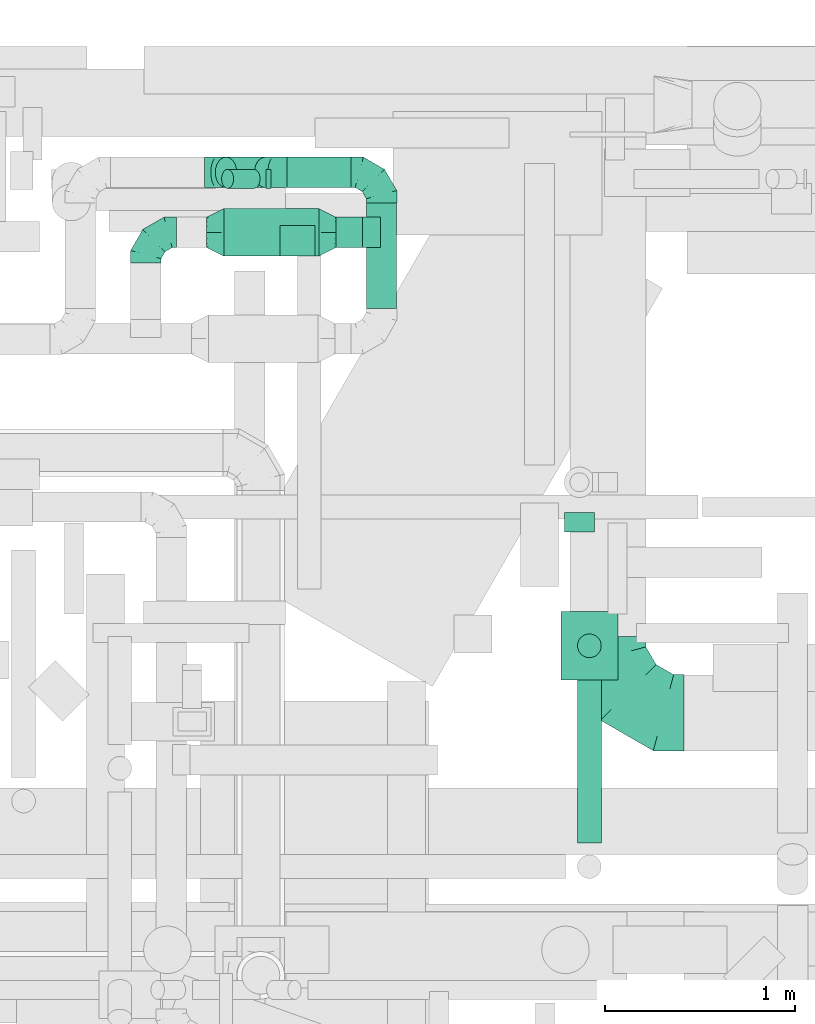
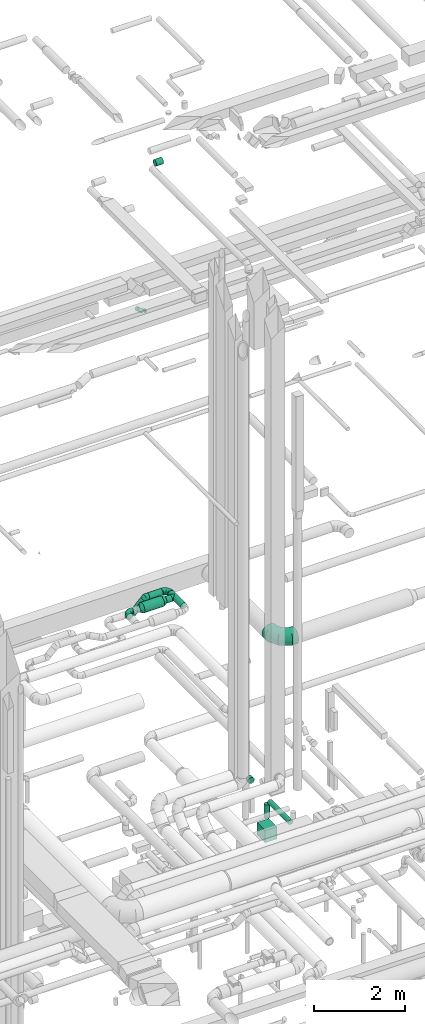
# One storey, part 288 of 337: 12 flow segments, 8 flow fittings.
"""IFC2X3 building model written with IfcOpenShell, lengths in millimetres."""

from ifc_helpers import new_model, entity, si_unit, converted_unit, derived_unit, direction, frame, origin, origin_2d_with_axis, place, context, subcontext, project, spatial, rectangle, circle, extrude, faceted_brep, source, transform, mapped, material, type_object, type_shapes, element, save


model = new_model("IFC2X3")

# Units and contexts
model_context = context("Model", 3, precision=0.01, world=origin(), true_north=direction((6.12303176911189e-17, 1.0)))
body_context = subcontext(model_context, "Body", "Model", "MODEL_VIEW")
ifc_project = project(units=[si_unit("LENGTHUNIT", "METRE", prefix="MILLI"), si_unit("AREAUNIT", "SQUARE_METRE"), si_unit("VOLUMEUNIT", "CUBIC_METRE"), converted_unit("PLANEANGLEUNIT", "DEGREE", entity("IfcRatioMeasure", 0.0174532925199433), si_unit("PLANEANGLEUNIT", "RADIAN"), dimensions=[0, 0, 0, 0, 0, 0, 0]), si_unit("MASSUNIT", "GRAM", prefix="KILO"), derived_unit("MASSDENSITYUNIT", [(si_unit("MASSUNIT", "GRAM", prefix="KILO"), 1), (si_unit("LENGTHUNIT", "METRE"), -3)]), derived_unit("MOMENTOFINERTIAUNIT", [(si_unit("LENGTHUNIT", "METRE"), 4)]), si_unit("TIMEUNIT", "SECOND"), si_unit("FREQUENCYUNIT", "HERTZ"), si_unit("THERMODYNAMICTEMPERATUREUNIT", "DEGREE_CELSIUS"), derived_unit("THERMALTRANSMITTANCEUNIT", [(si_unit("MASSUNIT", "GRAM", prefix="KILO"), 1), (si_unit("THERMODYNAMICTEMPERATUREUNIT", "KELVIN"), -1), (si_unit("TIMEUNIT", "SECOND"), -3)]), derived_unit("VOLUMETRICFLOWRATEUNIT", [(si_unit("LENGTHUNIT", "METRE"), 3), (si_unit("TIMEUNIT", "SECOND"), -1)]), derived_unit("MASSFLOWRATEUNIT", [(si_unit("MASSUNIT", "GRAM", prefix="KILO"), 1), (si_unit("TIMEUNIT", "SECOND"), -1)]), derived_unit("ROTATIONALFREQUENCYUNIT", [(si_unit("TIMEUNIT", "SECOND"), -1)]), si_unit("ELECTRICCURRENTUNIT", "AMPERE"), si_unit("ELECTRICVOLTAGEUNIT", "VOLT"), si_unit("POWERUNIT", "WATT"), si_unit("FORCEUNIT", "NEWTON", prefix="KILO"), si_unit("ILLUMINANCEUNIT", "LUX"), si_unit("LUMINOUSFLUXUNIT", "LUMEN"), si_unit("LUMINOUSINTENSITYUNIT", "CANDELA"), derived_unit("USERDEFINED", [(si_unit("MASSUNIT", "GRAM", prefix="KILO"), -1), (si_unit("LENGTHUNIT", "METRE"), -2), (si_unit("TIMEUNIT", "SECOND"), 3), (si_unit("LUMINOUSFLUXUNIT", "LUMEN"), 1)]), derived_unit("LINEARVELOCITYUNIT", [(si_unit("LENGTHUNIT", "METRE"), 1), (si_unit("TIMEUNIT", "SECOND"), -1)]), si_unit("PRESSUREUNIT", "PASCAL"), derived_unit("USERDEFINED", [(si_unit("LENGTHUNIT", "METRE"), -2), (si_unit("MASSUNIT", "GRAM", prefix="KILO"), 1), (si_unit("TIMEUNIT", "SECOND"), -2)]), derived_unit("LINEARFORCEUNIT", [(si_unit("MASSUNIT", "GRAM", prefix="KILO"), 1), (si_unit("LENGTHUNIT", "METRE"), 1), (si_unit("TIMEUNIT", "SECOND"), -2), (si_unit("LENGTHUNIT", "METRE"), -1)]), derived_unit("PLANARFORCEUNIT", [(si_unit("MASSUNIT", "GRAM", prefix="KILO"), 1), (si_unit("LENGTHUNIT", "METRE"), 1), (si_unit("TIMEUNIT", "SECOND"), -2), (si_unit("LENGTHUNIT", "METRE"), -2)])], contexts=[model_context])

# Site, building, storey
site_placement = place(None, origin())
site = spatial("IfcSite", under=ifc_project, at=site_placement, CompositionType="ELEMENT")
building_placement = place(site_placement, origin())
building = spatial("IfcBuilding", under=site, at=building_placement, CompositionType="ELEMENT")
storey_placement = place(building_placement, origin())
storey = spatial("IfcBuildingStorey", under=building, at=storey_placement, CompositionType="ELEMENT", Elevation=0.0)

# Flow segments
duct_segment_type_1 = type_object("IfcDuctSegmentType", PredefinedType="NOTDEFINED")
flow_segment_1_placement = place(storey_placement, frame((54966.59, 16768.43, -2020.0)))
element("IfcFlowSegment", 1, at=flow_segment_1_placement, inside=storey, type_object=duct_segment_type_1, context=body_context, shape_type="SweptSolid", body=[
    extrude(rectangle(XDim=300.000000000001, YDim=360.0, at=origin_2d_with_axis()), frame((150.0, 180.0, 0.0)), (0.0, 0.0, 1.0), 331.999999999989),
])
duct_segment_type_2 = type_object("IfcDuctSegmentType", PredefinedType="NOTDEFINED")
flow_segment_2_placement = place(storey_placement, frame((55052.5, 15911.72, -1064.1)))
element("IfcFlowSegment", 2, at=flow_segment_2_placement, inside=storey, type_object=duct_segment_type_2, context=body_context, shape_type="SweptSolid", body=[
    extrude(circle(Radius=62.5, at=origin_2d_with_axis()), frame((64.1, 0.0, 64.1), z_axis=(0.0, 1.0, 0.0), x_axis=(1.0, 0.0, 0.0)), (0.0, 0.0, 1.0), 911.706500000024),
])
flow_segment_3_placement = place(storey_placement, frame((55052.5, 16884.33, -1488.0)))
element("IfcFlowSegment", 3, at=flow_segment_3_placement, inside=storey, type_object=duct_segment_type_2, context=body_context, shape_type="SweptSolid", body=[
    extrude(circle(Radius=62.5, at=origin_2d_with_axis()), frame((64.1, 64.1, 0.0)), (0.0, 0.0, 1.0), 363.000000000013),
])
flow_segment_4_placement = place(storey_placement, frame((54982.68, 17547.0, -931.6)))
element("IfcFlowSegment", 4, at=flow_segment_4_placement, inside=storey, type_object=duct_segment_type_2, context=body_context, shape_type="SweptSolid", body=[
    extrude(circle(Radius=80.0, at=origin_2d_with_axis()), frame((81.6, 0.0, 81.6), z_axis=(0.0, 1.0, 0.0), x_axis=(1.0, 0.0, 0.0)), (0.0, 0.0, 1.0), 101.790010000019),
])
flow_segment_5_placement = place(storey_placement, frame((53180.36, 19353.19, 11224.5)))
element("IfcFlowSegment", 5, at=flow_segment_5_placement, inside=storey, type_object=duct_segment_type_2, context=body_context, shape_type="SweptSolid", body=[
    extrude(circle(Radius=50.0, at=origin_2d_with_axis()), frame((172.31, 51.6, 40.45), z_axis=(-0.777145961456963, 0.0, 0.629320391049847), x_axis=(0.0, -1.0, 0.0)), (0.0, 0.0, 1.0), 179.176285493916),
])
flow_segment_6_placement = place(storey_placement, frame((53415.6, 19353.19, 11191.07)))
element("IfcFlowSegment", 6, at=flow_segment_6_placement, inside=storey, type_object=duct_segment_type_2, context=body_context, shape_type="SweptSolid", body=[
    extrude(circle(Radius=50.0, at=origin_2d_with_axis()), frame((0.0, 51.6, 51.6), z_axis=(1.0, 0.0, 0.0), x_axis=(0.0, -1.0, 0.0)), (0.0, 0.0, 1.0), 27.2391711815912),
])
flow_segment_7_placement = place(storey_placement, frame((53489.91, 18997.31, 15308.4)))
element("IfcFlowSegment", 7, at=flow_segment_7_placement, inside=storey, type_object=duct_segment_type_2, context=body_context, shape_type="SweptSolid", body=[
    extrude(circle(Radius=80.0, at=origin_2d_with_axis()), frame((0.0, 81.6, 81.6), z_axis=(1.0, 0.0, 0.0), x_axis=(0.0, -1.0, 0.0)), (0.0, 0.0, 1.0), 184.053601638489),
])
flow_segment_8_placement = place(storey_placement, frame((53524.61, 19357.52, 3418.4)))
element("IfcFlowSegment", 8, at=flow_segment_8_placement, inside=storey, type_object=duct_segment_type_2, context=body_context, shape_type="SweptSolid", body=[
    extrude(circle(Radius=80.0, at=origin_2d_with_axis()), frame((0.0, 81.6, 81.6), z_axis=(1.0, 0.0, 0.0), x_axis=(0.0, -1.0, 0.0)), (0.0, 0.0, 1.0), 338.725830020326),
])
flow_segment_9_placement = place(storey_placement, frame((53941.74, 18724.11, 3418.4)))
element("IfcFlowSegment", 9, at=flow_segment_9_placement, inside=storey, type_object=duct_segment_type_2, context=body_context, shape_type="SweptSolid", body=[
    extrude(circle(Radius=80.0, at=origin_2d_with_axis()), frame((81.6, 0.0, 81.6), z_axis=(0.0, 1.0, 0.0), x_axis=(-1.0, 0.0, 0.0)), (0.0, 0.0, 1.0), 554.999999999945),
])
flow_segment_10_placement = place(storey_placement, frame((53147.04, 19357.52, 3188.7)))
element("IfcFlowSegment", 10, at=flow_segment_10_placement, inside=storey, type_object=duct_segment_type_2, context=body_context, shape_type="SweptSolid", body=[
    extrude(circle(Radius=80.0, at=origin_2d_with_axis()), frame((58.16, 81.6, 58.16), z_axis=(0.707106781186538, 0.0, 0.707106781186557), x_axis=(0.0, 1.0, 0.0)), (0.0, 0.0, 1.0), 291.715728752529),
])
flow_segment_11_placement = place(storey_placement, frame((53783.34, 19041.81, 3418.4)))
element("IfcFlowSegment", 11, at=flow_segment_11_placement, inside=storey, type_object=duct_segment_type_2, context=body_context, shape_type="SweptSolid", body=[
    extrude(circle(Radius=80.0, at=origin_2d_with_axis()), frame((0.0, 81.6, 81.6), z_axis=(1.0, 0.0, 0.0), x_axis=(0.0, 1.0, 0.0)), (0.0, 0.0, 1.0), 139.999999999986),
])
flow_segment_12_placement = place(storey_placement, frame((53193.34, 18996.81, 3373.4)))
element("IfcFlowSegment", 12, at=flow_segment_12_placement, inside=storey, type_object=duct_segment_type_2, context=body_context, shape_type="SweptSolid", body=[
    extrude(circle(Radius=125.0, at=origin_2d_with_axis()), frame((0.0, 126.6, 126.6), z_axis=(1.0, 0.0, 0.0), x_axis=(0.0, 1.0, 0.0)), (0.0, 0.0, 1.0), 499.99999999999),
])

# Flow fittings
ifc_material = material()
duct_fitting_type_1 = type_object("IfcDuctFittingType", PredefinedType="NOTDEFINED", material=ifc_material)
shared_shape_1 = source(origin(), body_context, "Body", "Brep", [
    faceted_brep([(-160.0, 0.0, -80.0), (-160.0, -20.71, -77.27), (-160.0, -40.0, -69.28), (-160.0, -56.57, -56.57), (-160.0, -69.28, -40.0), (-160.0, -77.27, -20.71), (-160.0, -80.0, 0.0), (-160.0, -77.27, 20.71), (-160.0, -69.28, 40.0), (-160.0, -56.57, 56.57), (-160.0, -40.0, 69.28), (-160.0, -20.71, 77.27), (-160.0, 0.0, 80.0), (-160.0, 20.71, 77.27), (-160.0, 40.0, 69.28), (-160.0, 56.57, 56.57), (-160.0, 69.28, 40.0), (-160.0, 77.27, 20.71), (-160.0, 80.0, 0.0), (-160.0, 77.27, -20.71), (-160.0, 69.28, -40.0), (-160.0, 56.57, -56.57), (-160.0, 40.0, -69.28), (-160.0, 20.71, -77.27), (-122.68, 20.71, 77.27), (-127.85, 40.0, 69.28), (-117.13, 0.0, 80.0), (-132.29, 56.57, 56.57), (-137.83, 77.27, 20.71), (-138.56, 80.0, 0.0), (-135.69, 69.28, 40.0), (-135.69, 69.28, -40.0), (-132.29, 56.57, -56.57), (-137.83, 77.27, -20.71), (-122.68, 20.71, -77.27), (-117.13, 0.0, -80.0), (-127.85, 40.0, -69.28), (-111.58, -20.71, -77.27), (-106.41, -40.0, -69.28), (-101.97, -56.57, -56.57), (-98.56, -69.28, -40.0), (-96.42, -77.27, -20.71), (-95.69, -80.0, 0.0), (-96.42, -77.27, 20.71), (-98.56, -69.28, 40.0), (-101.97, -56.57, 56.57), (-106.41, -40.0, 69.28), (-111.58, -20.71, 77.27), (-58.03, 58.03, 77.27), (-72.15, 72.15, 69.28), (-42.87, 42.87, 80.0), (-84.28, 84.28, 56.57), (-93.59, 93.59, 40.0), (-99.44, 99.44, 20.71), (-101.44, 101.44, 0.0), (-99.44, 99.44, -20.71), (-93.59, 93.59, -40.0), (-84.28, 84.28, -56.57), (-58.03, 58.03, -77.27), (-42.87, 42.87, -80.0), (-72.15, 72.15, -69.28), (-27.71, 27.71, -77.27), (-13.59, 13.59, -69.28), (-1.46, 1.46, -56.57), (7.85, -7.85, -40.0), (13.7, -13.7, -20.71), (15.69, -15.69, 0.0), (13.7, -13.7, 20.71), (7.85, -7.85, 40.0), (-1.46, 1.46, 56.57), (-13.59, 13.59, 69.28), (-27.71, 27.71, 77.27), (-20.71, 122.68, 77.27), (-40.0, 127.85, 69.28), (0.0, 117.13, 80.0), (-56.57, 132.29, 56.57), (-69.28, 135.69, 40.0), (-77.27, 137.83, 20.71), (-80.0, 138.56, 0.0), (-77.27, 137.83, -20.71), (-69.28, 135.69, -40.0), (-56.57, 132.29, -56.57), (-20.71, 122.68, -77.27), (0.0, 117.13, -80.0), (-40.0, 127.85, -69.28), (20.71, 111.58, -77.27), (40.0, 106.41, -69.28), (56.57, 101.97, -56.57), (69.28, 98.56, -40.0), (77.27, 96.42, -20.71), (80.0, 95.69, 0.0), (77.27, 96.42, 20.71), (69.28, 98.56, 40.0), (56.57, 101.97, 56.57), (40.0, 106.41, 69.28), (20.71, 111.58, 77.27), (-20.71, 160.0, -77.27), (-40.0, 160.0, -69.28), (-56.57, 160.0, -56.57), (-69.28, 160.0, -40.0), (-77.27, 160.0, -20.71), (-80.0, 160.0, 0.0), (-77.27, 160.0, 20.71), (-69.28, 160.0, 40.0), (-56.57, 160.0, 56.57), (-40.0, 160.0, 69.28), (-20.71, 160.0, 77.27), (0.0, 160.0, 80.0), (20.71, 160.0, 77.27), (40.0, 160.0, 69.28), (56.57, 160.0, 56.57), (69.28, 160.0, 40.0), (77.27, 160.0, 20.71), (80.0, 160.0, 0.0), (77.27, 160.0, -20.71), (69.28, 160.0, -40.0), (56.57, 160.0, -56.57), (40.0, 160.0, -69.28), (20.71, 160.0, -77.27), (0.0, 160.0, -80.0)], [[[0, 1, 2, 3, 4, 5, 6, 7, 8, 9, 10, 11, 12, 13, 14, 15, 16, 17, 18, 19, 20, 21, 22, 23]], [[24, 25, 14, 13]], [[26, 24, 13, 12]], [[14, 25, 27, 15]], [[28, 29, 18, 17]], [[30, 28, 17, 16]], [[15, 27, 30, 16]], [[20, 31, 32, 21]], [[33, 31, 20, 19]], [[18, 29, 33, 19]], [[34, 35, 0, 23]], [[36, 34, 23, 22]], [[32, 36, 22, 21]], [[1, 0, 35, 37]], [[2, 1, 37, 38]], [[3, 2, 38, 39]], [[5, 4, 40, 41]], [[6, 5, 41, 42]], [[39, 40, 4, 3]], [[6, 42, 43, 7]], [[7, 43, 44, 8]], [[8, 44, 45, 9]], [[9, 45, 46, 10]], [[10, 46, 47, 11]], [[26, 12, 11, 47]], [[48, 49, 25, 24]], [[50, 48, 24, 26]], [[27, 25, 49, 51]], [[52, 53, 28, 30]], [[51, 52, 30, 27]], [[29, 28, 53, 54]], [[55, 56, 31, 33]], [[54, 55, 33, 29]], [[32, 31, 56, 57]], [[58, 59, 35, 34]], [[60, 58, 34, 36]], [[57, 60, 36, 32]], [[37, 35, 59, 61]], [[38, 37, 61, 62]], [[39, 38, 62, 63]], [[41, 40, 64, 65]], [[42, 41, 65, 66]], [[63, 64, 40, 39]], [[43, 42, 66, 67]], [[44, 43, 67, 68]], [[68, 69, 45, 44]], [[46, 45, 69, 70]], [[47, 46, 70, 71]], [[26, 47, 71, 50]], [[72, 73, 49, 48]], [[74, 72, 48, 50]], [[51, 49, 73, 75]], [[76, 77, 53, 52]], [[75, 76, 52, 51]], [[54, 53, 77, 78]], [[79, 80, 56, 55]], [[78, 79, 55, 54]], [[57, 56, 80, 81]], [[82, 83, 59, 58]], [[84, 82, 58, 60]], [[81, 84, 60, 57]], [[61, 59, 83, 85]], [[62, 61, 85, 86]], [[63, 62, 86, 87]], [[65, 64, 88, 89]], [[66, 65, 89, 90]], [[87, 88, 64, 63]], [[67, 66, 90, 91]], [[68, 67, 91, 92]], [[92, 93, 69, 68]], [[70, 69, 93, 94]], [[71, 70, 94, 95]], [[50, 71, 95, 74]], [[96, 97, 98, 99, 100, 101, 102, 103, 104, 105, 106, 107, 108, 109, 110, 111, 112, 113, 114, 115, 116, 117, 118, 119]], [[72, 74, 107, 106]], [[73, 72, 106, 105]], [[75, 73, 105, 104]], [[77, 76, 103, 102]], [[78, 77, 102, 101]], [[75, 104, 103, 76]], [[78, 101, 100, 79]], [[79, 100, 99, 80]], [[80, 99, 98, 81]], [[84, 97, 96, 82]], [[82, 96, 119, 83]], [[84, 81, 98, 97]], [[118, 117, 86, 85]], [[119, 118, 85, 83]], [[116, 87, 86, 117]], [[88, 115, 114, 89]], [[89, 114, 113, 90]], [[115, 88, 87, 116]], [[112, 111, 92, 91]], [[113, 112, 91, 90]], [[111, 110, 93, 92]], [[95, 94, 109, 108]], [[74, 95, 108, 107]], [[110, 109, 94, 93]]]),
])
type_shapes(duct_fitting_type_1, [shared_shape_1])
for number, where, z_axis, x_axis in (
    (13, (54023.34, 19439.11, 3500.0), (0.0, 0.0, 1.0), (0.0, 1.0, 0.0)),
    (14, (52783.34, 19123.41, 3500.0), (0.0, 0.0, 1.0), (-1.0, 0.0, 0.0)),
):
    element("IfcFlowFitting", number, at=place(storey_placement, frame(where, z_axis=z_axis, x_axis=x_axis)), inside=storey, type_object=duct_fitting_type_1, material=ifc_material, context=body_context, shape_type="MappedRepresentation", body=[
        mapped(shared_shape_1, transform((0.0, 0.0, 0.0), scale=1.0)),
    ])
duct_fitting_type_2 = type_object("IfcDuctFittingType", PredefinedType="NOTDEFINED", material=ifc_material)
shared_shape_2 = source(origin(), body_context, "Body", "Brep", [
    faceted_brep([(-400.0, 0.0, -200.0), (-400.0, -44.5, -194.99), (-400.0, -86.78, -180.19), (-400.0, -124.7, -156.37), (-400.0, -156.37, -124.7), (-400.0, -180.19, -86.78), (-400.0, -194.99, -44.5), (-400.0, -200.0, 0.0), (-400.0, -194.99, 44.5), (-400.0, -180.19, 86.78), (-400.0, -156.37, 124.7), (-400.0, -124.7, 156.37), (-400.0, -86.78, 180.19), (-400.0, -44.5, 194.99), (-400.0, 0.0, 200.0), (-400.0, 44.5, 194.99), (-400.0, 86.78, 180.19), (-400.0, 124.7, 156.37), (-400.0, 156.37, 124.7), (-400.0, 180.19, 86.78), (-400.0, 194.99, 44.5), (-400.0, 200.0, 0.0), (-400.0, 194.99, -44.5), (-400.0, 180.19, -86.78), (-400.0, 156.37, -124.7), (-400.0, 124.7, -156.37), (-400.0, 86.78, -180.19), (-400.0, 44.5, -194.99), (-292.82, 0.0, 200.0), (-304.75, 44.5, 194.99), (-316.07, 86.78, 180.19), (-326.23, 124.7, 156.37), (-334.72, 156.37, 124.7), (-341.1, 180.19, 86.78), (-345.07, 194.99, 44.5), (-346.41, 200.0, 0.0), (-345.07, 194.99, -44.5), (-341.1, 180.19, -86.78), (-334.72, 156.37, -124.7), (-326.23, 124.7, -156.37), (-316.07, 86.78, -180.19), (-304.75, 44.5, -194.99), (-292.82, 0.0, -200.0), (-280.9, -44.5, -194.99), (-269.57, -86.78, -180.19), (-259.41, -124.7, -156.37), (-250.92, -156.37, -124.7), (-244.54, -180.19, -86.78), (-240.57, -194.99, -44.5), (-239.23, -200.0, 0.0), (-240.57, -194.99, 44.5), (-244.54, -180.19, 86.78), (-250.92, -156.37, 124.7), (-259.41, -124.7, 156.37), (-269.57, -86.78, 180.19), (-280.9, -44.5, 194.99), (-107.18, 107.18, 200.0), (-139.76, 139.76, 194.99), (-170.7, 170.7, 180.19), (-198.46, 198.46, 156.37), (-221.65, 221.65, 124.7), (-239.09, 239.09, 86.78), (-249.92, 249.92, 44.5), (-253.59, 253.59, 0.0), (-249.92, 249.92, -44.5), (-239.09, 239.09, -86.78), (-221.65, 221.65, -124.7), (-198.46, 198.46, -156.37), (-170.7, 170.7, -180.19), (-139.76, 139.76, -194.99), (-107.18, 107.18, -200.0), (-74.6, 74.6, -194.99), (-43.65, 43.65, -180.19), (-15.89, 15.89, -156.37), (7.29, -7.29, -124.7), (24.73, -24.73, -86.78), (35.56, -35.56, -44.5), (39.23, -39.23, 0.0), (35.56, -35.56, 44.5), (24.73, -24.73, 86.78), (7.29, -7.29, 124.7), (-15.89, 15.89, 156.37), (-43.65, 43.65, 180.19), (-74.6, 74.6, 194.99), (0.0, 292.82, 200.0), (-44.5, 304.75, 194.99), (-86.78, 316.07, 180.19), (-124.7, 326.23, 156.37), (-156.37, 334.72, 124.7), (-180.19, 341.1, 86.78), (-194.99, 345.07, 44.5), (-200.0, 346.41, 0.0), (-194.99, 345.07, -44.5), (-180.19, 341.1, -86.78), (-156.37, 334.72, -124.7), (-124.7, 326.23, -156.37), (-86.78, 316.07, -180.19), (-44.5, 304.75, -194.99), (0.0, 292.82, -200.0), (44.5, 280.9, -194.99), (86.78, 269.57, -180.19), (124.7, 259.41, -156.37), (156.37, 250.92, -124.7), (180.19, 244.54, -86.78), (194.99, 240.57, -44.5), (200.0, 239.23, 0.0), (194.99, 240.57, 44.5), (180.19, 244.54, 86.78), (156.37, 250.92, 124.7), (124.7, 259.41, 156.37), (86.78, 269.57, 180.19), (44.5, 280.9, 194.99), (-44.5, 400.0, -194.99), (-86.78, 400.0, -180.19), (-124.7, 400.0, -156.37), (-156.37, 400.0, -124.7), (-180.19, 400.0, -86.78), (-194.99, 400.0, -44.5), (-200.0, 400.0, 0.0), (-194.99, 400.0, 44.5), (-180.19, 400.0, 86.78), (-156.37, 400.0, 124.7), (-124.7, 400.0, 156.37), (-86.78, 400.0, 180.19), (-44.5, 400.0, 194.99), (0.0, 400.0, 200.0), (44.5, 400.0, 194.99), (86.78, 400.0, 180.19), (124.7, 400.0, 156.37), (156.37, 400.0, 124.7), (180.19, 400.0, 86.78), (194.99, 400.0, 44.5), (200.0, 400.0, 0.0), (194.99, 400.0, -44.5), (180.19, 400.0, -86.78), (156.37, 400.0, -124.7), (124.7, 400.0, -156.37), (86.78, 400.0, -180.19), (44.5, 400.0, -194.99), (0.0, 400.0, -200.0)], [[[0, 1, 2, 3, 4, 5, 6, 7, 8, 9, 10, 11, 12, 13, 14, 15, 16, 17, 18, 19, 20, 21, 22, 23, 24, 25, 26, 27]], [[28, 29, 15, 14]], [[30, 31, 17, 16]], [[29, 30, 16, 15]], [[31, 32, 18, 17]], [[32, 33, 19, 18]], [[34, 35, 21, 20]], [[33, 34, 20, 19]], [[35, 36, 22, 21]], [[37, 38, 24, 23]], [[36, 37, 23, 22]], [[38, 39, 25, 24]], [[39, 40, 26, 25]], [[41, 42, 0, 27]], [[40, 41, 27, 26]], [[1, 0, 42, 43]], [[43, 44, 2, 1]], [[45, 3, 2, 44]], [[45, 46, 4, 3]], [[5, 4, 46, 47]], [[47, 48, 6, 5]], [[49, 7, 6, 48]], [[7, 49, 50, 8]], [[8, 50, 51, 9]], [[9, 51, 52, 10]], [[52, 53, 11, 10]], [[11, 53, 54, 12]], [[12, 54, 55, 13]], [[13, 55, 28, 14]], [[56, 57, 29, 28]], [[58, 59, 31, 30]], [[57, 58, 30, 29]], [[59, 60, 32, 31]], [[60, 61, 33, 32]], [[62, 63, 35, 34]], [[61, 62, 34, 33]], [[63, 64, 36, 35]], [[65, 66, 38, 37]], [[64, 65, 37, 36]], [[66, 67, 39, 38]], [[67, 68, 40, 39]], [[69, 70, 42, 41]], [[68, 69, 41, 40]], [[43, 42, 70, 71]], [[71, 72, 44, 43]], [[73, 45, 44, 72]], [[73, 74, 46, 45]], [[47, 46, 74, 75]], [[75, 76, 48, 47]], [[77, 49, 48, 76]], [[50, 49, 77, 78]], [[51, 50, 78, 79]], [[52, 51, 79, 80]], [[80, 81, 53, 52]], [[54, 53, 81, 82]], [[55, 54, 82, 83]], [[28, 55, 83, 56]], [[84, 85, 57, 56]], [[86, 87, 59, 58]], [[85, 86, 58, 57]], [[87, 88, 60, 59]], [[88, 89, 61, 60]], [[90, 91, 63, 62]], [[89, 90, 62, 61]], [[91, 92, 64, 63]], [[93, 94, 66, 65]], [[92, 93, 65, 64]], [[94, 95, 67, 66]], [[95, 96, 68, 67]], [[97, 98, 70, 69]], [[96, 97, 69, 68]], [[71, 70, 98, 99]], [[99, 100, 72, 71]], [[101, 73, 72, 100]], [[101, 102, 74, 73]], [[75, 74, 102, 103]], [[103, 104, 76, 75]], [[105, 77, 76, 104]], [[78, 77, 105, 106]], [[79, 78, 106, 107]], [[80, 79, 107, 108]], [[108, 109, 81, 80]], [[82, 81, 109, 110]], [[83, 82, 110, 111]], [[56, 83, 111, 84]], [[112, 113, 114, 115, 116, 117, 118, 119, 120, 121, 122, 123, 124, 125, 126, 127, 128, 129, 130, 131, 132, 133, 134, 135, 136, 137, 138, 139]], [[85, 84, 125, 124]], [[86, 85, 124, 123]], [[87, 86, 123, 122]], [[122, 121, 88, 87]], [[89, 88, 121, 120]], [[90, 89, 120, 119]], [[91, 90, 119, 118]], [[91, 118, 117, 92]], [[92, 117, 116, 93]], [[93, 116, 115, 94]], [[115, 114, 95, 94]], [[95, 114, 113, 96]], [[96, 113, 112, 97]], [[97, 112, 139, 98]], [[98, 139, 138, 99]], [[99, 138, 137, 100]], [[100, 137, 136, 101]], [[136, 135, 102, 101]], [[102, 135, 134, 103]], [[103, 134, 133, 104]], [[104, 133, 132, 105]], [[106, 105, 132, 131]], [[107, 106, 131, 130]], [[108, 107, 130, 129]], [[129, 128, 109, 108]], [[110, 109, 128, 127]], [[111, 110, 127, 126]], [[84, 111, 126, 125]]]),
])
type_shapes(duct_fitting_type_2, [shared_shape_2])
flow_fitting_1_placement = place(storey_placement, frame((55213.74, 16596.24, 3450.0), z_axis=(0.0, 0.0, 1.0), x_axis=(0.0, -1.0, 0.0)))
element("IfcFlowFitting", 15, at=flow_fitting_1_placement, inside=storey, type_object=duct_fitting_type_2, material=ifc_material, context=body_context, shape_type="MappedRepresentation", body=[
    mapped(shared_shape_2, transform((0.0, 0.0, 0.0), scale=1.0)),
])
duct_fitting_type_3 = type_object("IfcDuctFittingType", PredefinedType="NOTDEFINED", material=ifc_material)
shared_shape_3 = source(origin(), body_context, "Body", "Brep", [
    faceted_brep([(-66.27, 0.0, -80.0), (-66.27, -20.71, -77.27), (-66.27, -40.0, -69.28), (-66.27, -56.57, -56.57), (-66.27, -69.28, -40.0), (-66.27, -77.27, -20.71), (-66.27, -80.0, 0.0), (-66.27, -77.27, 20.71), (-66.27, -69.28, 40.0), (-66.27, -56.57, 56.57), (-66.27, -40.0, 69.28), (-66.27, -20.71, 77.27), (-66.27, 0.0, 80.0), (-66.27, 20.71, 77.27), (-66.27, 40.0, 69.28), (-66.27, 56.57, 56.57), (-66.27, 69.28, 40.0), (-66.27, 77.27, 20.71), (-66.27, 80.0, 0.0), (-66.27, 77.27, -20.71), (-66.27, 69.28, -40.0), (-66.27, 56.57, -56.57), (-66.27, 40.0, -69.28), (-66.27, 20.71, -77.27), (-8.58, 20.71, 77.27), (-16.57, 40.0, 69.28), (0.0, 0.0, 80.0), (-23.43, 56.57, 56.57), (-28.7, 69.28, 40.0), (-32.01, 77.27, 20.71), (-33.14, 80.0, 0.0), (-32.01, 77.27, -20.71), (-28.7, 69.28, -40.0), (-23.43, 56.57, -56.57), (-8.58, 20.71, -77.27), (0.0, 0.0, -80.0), (-16.57, 40.0, -69.28), (8.58, -20.71, -77.27), (16.57, -40.0, -69.28), (23.43, -56.57, -56.57), (28.7, -69.28, -40.0), (32.01, -77.27, -20.71), (33.14, -80.0, 0.0), (32.01, -77.27, 20.71), (28.7, -69.28, 40.0), (23.43, -56.57, 56.57), (16.57, -40.0, 69.28), (8.58, -20.71, 77.27), (46.86, 46.86, 80.0), (32.22, 61.5, 77.27), (18.58, 75.15, 69.28), (6.86, 86.86, 56.57), (-2.13, 95.85, 40.0), (-7.78, 101.5, 20.71), (-9.71, 103.43, 0.0), (-7.78, 101.5, -20.71), (-2.13, 95.85, -40.0), (6.86, 86.86, -56.57), (18.58, 75.15, -69.28), (32.22, 61.5, -77.27), (46.86, 46.86, -80.0), (61.5, 32.22, -77.27), (75.15, 18.58, -69.28), (86.86, 6.86, -56.57), (95.85, -2.13, -40.0), (101.5, -7.78, -20.71), (103.43, -9.71, 0.0), (101.5, -7.78, 20.71), (95.85, -2.13, 40.0), (86.86, 6.86, 56.57), (75.15, 18.58, 69.28), (61.5, 32.22, 77.27)], [[[0, 1, 2, 3, 4, 5, 6, 7, 8, 9, 10, 11, 12, 13, 14, 15, 16, 17, 18, 19, 20, 21, 22, 23]], [[24, 25, 14, 13]], [[26, 24, 13, 12]], [[14, 25, 27, 15]], [[28, 29, 17, 16]], [[28, 16, 15, 27]], [[30, 18, 17, 29]], [[31, 32, 20, 19]], [[30, 31, 19, 18]], [[32, 33, 21, 20]], [[34, 35, 0, 23]], [[36, 34, 23, 22]], [[33, 36, 22, 21]], [[1, 0, 35, 37]], [[2, 1, 37, 38]], [[38, 39, 3, 2]], [[5, 4, 40, 41]], [[6, 5, 41, 42]], [[39, 40, 4, 3]], [[6, 42, 43, 7]], [[7, 43, 44, 8]], [[8, 44, 45, 9]], [[9, 45, 46, 10]], [[10, 46, 47, 11]], [[26, 12, 11, 47]], [[24, 26, 48, 49]], [[25, 24, 49, 50]], [[27, 25, 50, 51]], [[29, 28, 52, 53]], [[30, 29, 53, 54]], [[51, 52, 28, 27]], [[30, 54, 55, 31]], [[31, 55, 56, 32]], [[57, 33, 32, 56]], [[36, 58, 59, 34]], [[34, 59, 60, 35]], [[58, 36, 33, 57]], [[35, 60, 61, 37]], [[37, 61, 62, 38]], [[63, 39, 38, 62]], [[40, 64, 65, 41]], [[41, 65, 66, 42]], [[64, 40, 39, 63]], [[43, 42, 66, 67]], [[44, 43, 67, 68]], [[68, 69, 45, 44]], [[47, 46, 70, 71]], [[26, 47, 71, 48]], [[69, 70, 46, 45]], [[59, 58, 57, 56, 55, 54, 53, 52, 51, 50, 49, 48, 71, 70, 69, 68, 67, 66, 65, 64, 63, 62, 61, 60]]]),
])
type_shapes(duct_fitting_type_3, [shared_shape_3])
for number, where, z_axis, x_axis in (
    (16, (53458.34, 19439.11, 3500.0), (0.0, -1.0, 0.0), (-1.0, 0.0, 0.0)),
    (17, (53158.34, 19439.11, 3200.0), (0.0, -1.0, 0.0), (1.0, 0.0, 0.0)),
):
    element("IfcFlowFitting", number, at=place(storey_placement, frame(where, z_axis=z_axis, x_axis=x_axis)), inside=storey, type_object=duct_fitting_type_3, material=ifc_material, context=body_context, shape_type="MappedRepresentation", body=[
        mapped(shared_shape_3, transform((0.0, 0.0, 0.0), scale=1.0)),
    ])
duct_fitting_type_4 = type_object("IfcDuctFittingType", PredefinedType="NOTDEFINED", material=ifc_material)
shared_shape_4 = source(origin(), body_context, "Body", "Brep", [
    faceted_brep([(20.0, 20.71, -77.27), (20.0, 40.0, -69.28), (20.0, 56.57, -56.57), (20.0, 69.28, -40.0), (20.0, 77.27, -20.71), (20.0, 80.0, 0.0), (20.0, 77.27, 20.71), (20.0, 69.28, 40.0), (20.0, 56.57, 56.57), (20.0, 40.0, 69.28), (20.0, 20.71, 77.27), (20.0, 0.0, 80.0), (20.0, -20.71, 77.27), (20.0, -40.0, 69.28), (20.0, -56.57, 56.57), (20.0, -69.28, 40.0), (20.0, -77.27, 20.71), (20.0, -80.0, 0.0), (20.0, -77.27, -20.71), (20.0, -69.28, -40.0), (20.0, -56.57, -56.57), (20.0, -40.0, -69.28), (20.0, -20.71, -77.27), (20.0, 0.0, -80.0), (0.0, 0.0, 80.0), (0.0, 20.71, 77.27), (-73.9, 20.71, 77.27), (-73.9, 0.0, 80.0), (0.0, 40.0, 69.28), (-73.9, 40.0, 69.28), (0.0, 56.57, 56.57), (-73.9, 56.57, 56.57), (0.0, 69.28, 40.0), (0.0, 77.27, 20.71), (-73.9, 77.27, 20.71), (-73.9, 69.28, 40.0), (0.0, 80.0, 0.0), (-73.9, 80.0, 0.0), (0.0, 77.27, -20.71), (-73.9, 77.27, -20.71), (0.0, 69.28, -40.0), (-73.9, 69.28, -40.0), (0.0, 56.57, -56.57), (-73.9, 56.57, -56.57), (0.0, 40.0, -69.28), (0.0, 20.71, -77.27), (-73.9, 20.71, -77.27), (-73.9, 40.0, -69.28), (0.0, 0.0, -80.0), (-73.9, 0.0, -80.0), (0.0, -20.71, -77.27), (-73.9, -20.71, -77.27), (0.0, -40.0, -69.28), (-73.9, -40.0, -69.28), (0.0, -56.57, -56.57), (-73.9, -56.57, -56.57), (0.0, -69.28, -40.0), (0.0, -77.27, -20.71), (-73.9, -77.27, -20.71), (-73.9, -69.28, -40.0), (0.0, -80.0, 0.0), (-73.9, -80.0, 0.0), (0.0, -77.27, 20.71), (-73.9, -77.27, 20.71), (0.0, -69.28, 40.0), (-73.9, -69.28, 40.0), (0.0, -56.57, 56.57), (-73.9, -56.57, 56.57), (0.0, -40.0, 69.28), (0.0, -20.71, 77.27), (-73.9, -20.71, 77.27), (-73.9, -40.0, 69.28)], [[[0, 1, 2, 3, 4, 5, 6, 7, 8, 9, 10, 11, 12, 13, 14, 15, 16, 17, 18, 19, 20, 21, 22, 23]], [[24, 11, 10, 25, 26, 27]], [[25, 10, 9, 28, 29, 26]], [[28, 9, 8, 30, 31, 29]], [[32, 7, 6, 33, 34, 35]], [[33, 6, 5, 36, 37, 34]], [[30, 8, 7, 32, 35, 31]], [[36, 5, 4, 38, 39, 37]], [[38, 4, 3, 40, 41, 39]], [[40, 3, 2, 42, 43, 41]], [[44, 1, 0, 45, 46, 47]], [[45, 0, 23, 48, 49, 46]], [[42, 2, 1, 44, 47, 43]], [[48, 23, 22, 50, 51, 49]], [[50, 22, 21, 52, 53, 51]], [[52, 21, 20, 54, 55, 53]], [[56, 19, 18, 57, 58, 59]], [[57, 18, 17, 60, 61, 58]], [[54, 20, 19, 56, 59, 55]], [[60, 17, 16, 62, 63, 61]], [[62, 16, 15, 64, 65, 63]], [[64, 15, 14, 66, 67, 65]], [[68, 13, 12, 69, 70, 71]], [[69, 12, 11, 24, 27, 70]], [[66, 14, 13, 68, 71, 67]], [[49, 51, 53, 55, 59, 58, 61, 63, 65, 67, 71, 70, 27, 26, 29, 31, 35, 34, 37, 39, 41, 43, 47, 46]]]),
])
type_shapes(duct_fitting_type_4, [shared_shape_4])
flow_fitting_2_placement = place(storey_placement, frame((53943.34, 19123.41, 3500.0), z_axis=(0.0, 0.0, -1.0), x_axis=(-1.0, 0.0, 0.0)))
element("IfcFlowFitting", 18, at=flow_fitting_2_placement, inside=storey, type_object=duct_fitting_type_4, material=ifc_material, context=body_context, shape_type="MappedRepresentation", body=[
    mapped(shared_shape_4, transform((0.0, 0.0, 0.0), scale=1.0)),
])
duct_fitting_type_5 = type_object("IfcDuctFittingType", PredefinedType="NOTDEFINED", material=ifc_material)
shared_shape_5 = source(origin(), body_context, "Body", "Brep", [
    faceted_brep([(90.0, -73.47, -101.13), (90.0, -38.63, -118.88), (90.0, 0.0, -125.0), (90.0, 38.63, -118.88), (90.0, 73.47, -101.13), (90.0, 101.13, -73.47), (90.0, 118.88, -38.63), (90.0, 125.0, 0.0), (90.0, 118.88, 38.63), (90.0, 101.13, 73.47), (90.0, 73.47, 101.13), (90.0, 38.63, 118.88), (90.0, 0.0, 125.0), (90.0, -38.63, 118.88), (90.0, -73.47, 101.13), (90.0, -101.13, 73.47), (90.0, -118.88, 38.63), (90.0, -125.0, 0.0), (90.0, -118.88, -38.63), (90.0, -101.13, -73.47), (0.0, -30.61, -73.91), (0.0, -43.59, -65.24), (0.0, -56.57, -56.57), (0.0, -65.24, -43.59), (0.0, -73.91, -30.61), (0.0, -76.96, -15.31), (0.0, -80.0, 0.0), (0.0, -76.96, 15.31), (0.0, -73.91, 30.61), (0.0, -65.24, 43.59), (0.0, -56.57, 56.57), (0.0, -43.59, 65.24), (0.0, -30.61, 73.91), (0.0, -15.31, 76.96), (0.0, 0.0, 80.0), (0.0, 15.31, 76.96), (0.0, 30.61, 73.91), (0.0, 43.59, 65.24), (0.0, 56.57, 56.57), (0.0, 65.24, 43.59), (0.0, 73.91, 30.61), (0.0, 76.96, 15.31), (0.0, 80.0, 0.0), (0.0, 76.96, -15.31), (0.0, 73.91, -30.61), (0.0, 65.24, -43.59), (0.0, 56.57, -56.57), (0.0, 43.59, -65.24), (0.0, 30.61, -73.91), (0.0, 15.31, -76.96), (0.0, 0.0, -80.0), (0.0, -15.31, -76.96)], [[[0, 1, 2, 3, 4, 5, 6, 7, 8, 9, 10, 11, 12, 13, 14, 15, 16, 17, 18, 19]], [[20, 21, 22, 23, 24, 25, 26, 27, 28, 29, 30, 31, 32, 33, 34, 35, 36, 37, 38, 39, 40, 41, 42, 43, 44, 45, 46, 47, 48, 49, 50, 51]], [[7, 41, 8]], [[41, 40, 8]], [[40, 9, 8]], [[11, 36, 35]], [[41, 7, 42]], [[9, 40, 39, 38]], [[10, 38, 37, 36]], [[12, 35, 34]], [[11, 10, 36]], [[12, 11, 35]], [[38, 10, 9]], [[12, 33, 13]], [[33, 32, 13]], [[32, 14, 13]], [[16, 28, 27]], [[33, 12, 34]], [[14, 32, 31, 30]], [[15, 30, 29, 28]], [[17, 27, 26]], [[16, 15, 28]], [[17, 16, 27]], [[30, 15, 14]], [[17, 25, 18]], [[25, 24, 18]], [[24, 19, 18]], [[1, 20, 51]], [[25, 17, 26]], [[19, 24, 23, 22]], [[0, 22, 21, 20]], [[2, 51, 50]], [[1, 0, 20]], [[2, 1, 51]], [[22, 0, 19]], [[2, 49, 3]], [[49, 48, 3]], [[48, 4, 3]], [[6, 44, 43]], [[49, 2, 50]], [[4, 48, 47, 46]], [[5, 46, 45, 44]], [[7, 43, 42]], [[6, 5, 44]], [[7, 6, 43]], [[46, 5, 4]]]),
])
type_shapes(duct_fitting_type_5, [shared_shape_5])
flow_fitting_3_placement = place(storey_placement, frame((53783.34, 19123.41, 3500.0), z_axis=(0.0, 0.0, 1.0), x_axis=(-1.0, 0.0, 0.0)))
element("IfcFlowFitting", 19, at=flow_fitting_3_placement, inside=storey, type_object=duct_fitting_type_5, material=ifc_material, context=body_context, shape_type="MappedRepresentation", body=[
    mapped(shared_shape_5, transform((0.0, 0.0, 0.0), scale=1.0)),
])
flow_fitting_4_placement = place(storey_placement, frame((53103.34, 19123.41, 3500.0)))
element("IfcFlowFitting", 20, at=flow_fitting_4_placement, inside=storey, type_object=duct_fitting_type_5, material=ifc_material, context=body_context, shape_type="MappedRepresentation", body=[
    mapped(shared_shape_5, transform((0.0, 0.0, 0.0), scale=1.0)),
])

save(model, "model.ifc")
